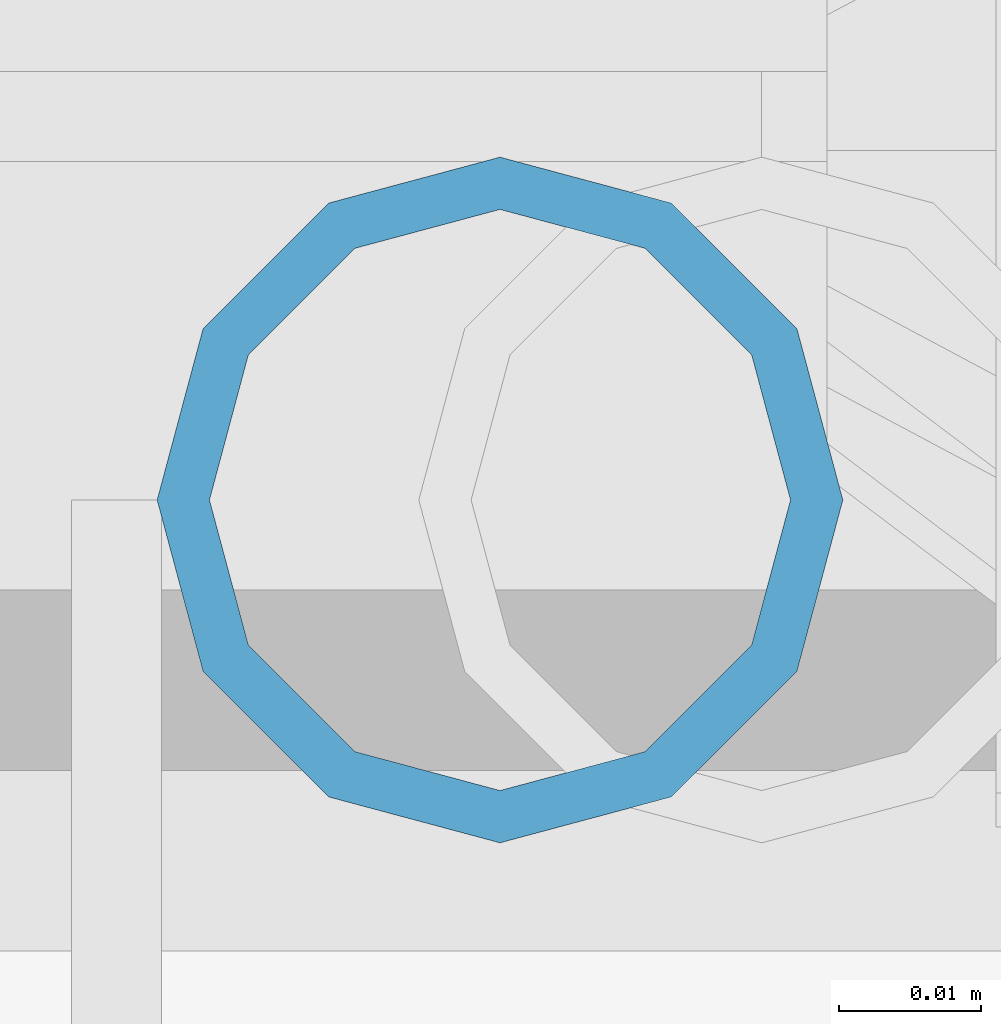
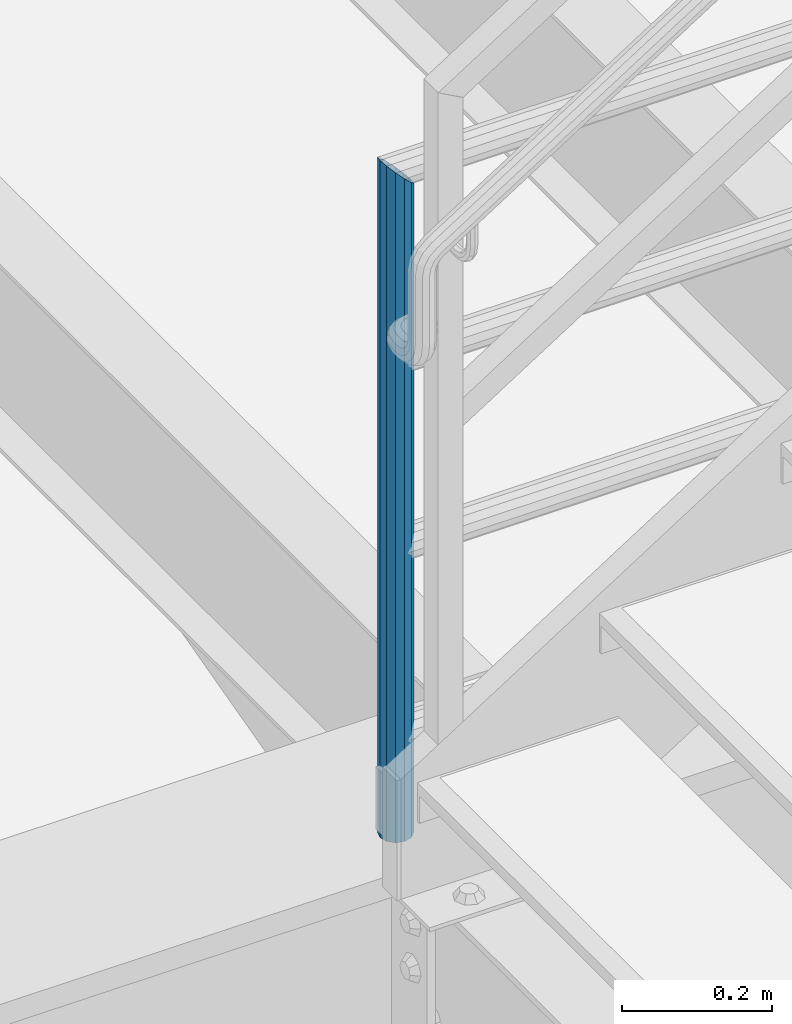
# One storey, part 608 of 1876: 1 column, 1 element without a shape of its own.
"""IFC2X3 building model written with IfcOpenShell, lengths in millimetres."""

from ifc_helpers import new_model, si_unit, frame, origin_with_axes, place, context, subcontext, project, spatial, faceted_brep, material, type_object, element, aggregate, save


model = new_model("IFC2X3")

# Units and contexts
model_context = context("Model", 3, precision=1e-05, world=origin_with_axes())
body_context = subcontext(model_context, "Body", "Model", "MODEL_VIEW")
ifc_project = project(units=[si_unit("LENGTHUNIT", "METRE", prefix="MILLI"), si_unit("AREAUNIT", "SQUARE_METRE"), si_unit("VOLUMEUNIT", "CUBIC_METRE"), si_unit("MASSUNIT", "GRAM", prefix="KILO"), si_unit("TIMEUNIT", "SECOND"), si_unit("PLANEANGLEUNIT", "RADIAN"), si_unit("SOLIDANGLEUNIT", "STERADIAN"), si_unit("THERMODYNAMICTEMPERATUREUNIT", "DEGREE_CELSIUS"), si_unit("LUMINOUSINTENSITYUNIT", "LUMEN")], contexts=[model_context])

# Site, building, storey
site_placement = place(None, origin_with_axes())
site = spatial("IfcSite", under=ifc_project, at=site_placement, CompositionType="ELEMENT")
building_placement = place(site_placement, origin_with_axes())
building = spatial("IfcBuilding", under=site, at=building_placement, Name="Undefined", CompositionType="ELEMENT")
storey_placement = place(building_placement, origin_with_axes())
storey = spatial("IfcBuildingStorey", under=building, at=storey_placement, Name="Undefined", CompositionType="ELEMENT", Elevation=0.0)

# Assembly, column
assembly_placement = place(storey_placement, origin_with_axes())
assembly = element("IfcElementAssembly", 1, at=assembly_placement, inside=storey, Name="RAIL", AssemblyPlace="NOTDEFINED", PredefinedType="RIGID_FRAME")
ifc_material = material()
column_type = type_object("IfcColumnType", Name="PIPE1-1/2SCH40", PredefinedType="NOTDEFINED")
column_placement = place(assembly_placement, frame((1676.40000031139, -4654.55000114554, 5130.8), z_axis=(1.0, 0.0, 0.0), x_axis=(0.0, 0.0, 1.0)))
column = element("IfcColumn", 2, at=column_placement, type_object=column_type, material=ifc_material, Name="POST", ObjectType="PIPE1-1/2SCH40", context=body_context, shape_type="Brep", body=[
    faceted_brep([(0.0, -20.4469999999999, 0.0), (0.0, -17.7076214311803, 10.2235000000001), (1066.1015, -17.7076214311803, 10.2235000000001), (1076.325, -20.4469999999999, 0.0), (0.0, -10.2235000000001, 17.7076214311801), (1058.61737856882, -10.2235000000001, 17.7076214311801), (-1.45519152283669e-11, 0.0, 20.4470000000001), (1055.878, 0.0, 20.4470000000001), (0.0, 10.2235000000001, 17.7076214311801), (1058.61737856882, 10.2235000000001, 17.7076214311801), (0.0, 17.7076214311803, 10.2235000000001), (1066.1015, 17.7076214311803, 10.2235000000001), (0.0, 20.4469999999999, 0.0), (1076.325, 20.4469999999999, 0.0), (0.0, 17.7076214311803, -10.2235000000001), (1086.5485, 17.7076214311803, -10.2235000000001), (0.0, 10.2235000000001, -17.7076214311801), (1094.03262143118, 10.2235000000001, -17.7076214311801), (-1.45519152283669e-11, 0.0, -20.4470000000001), (1096.772, 0.0, -20.4470000000001), (0.0, -10.2235000000001, -17.7076214311801), (1094.03262143118, -10.2235000000001, -17.7076214311801), (0.0, -17.7076214311803, -10.2235000000001), (1086.5485, -17.7076214311803, -10.2235000000001), (0.0, -24.1299999999992, 0.0), (0.0, -20.8971929933184, -12.0649999999996), (1088.39, -20.8971929933184, -12.0649999999996), (1076.325, -24.1300000000001, 0.0), (0.0, -12.0650000000001, -20.8971929933186), (1097.22219299332, -12.0650000000001, -20.8971929933186), (-1.45519152283669e-11, 0.0, -24.130000000001), (1100.455, 0.0, -24.1300000000001), (0.0, 12.0650000000001, -20.8971929933186), (1097.22219299332, 12.0650000000001, -20.8971929933186), (0.0, 20.8971929933184, -12.0649999999996), (1088.39, 20.8971929933184, -12.0649999999996), (0.0, 24.1299999999992, 0.0), (1076.325, 24.1300000000001, 0.0), (0.0, 20.8971929933184, 12.0649999999996), (1064.26, 20.8971929933184, 12.0649999999996), (0.0, 12.0650000000001, 20.8971929933186), (1055.42780700668, 12.0650000000001, 20.8971929933186), (-1.45519152283669e-11, 0.0, 24.130000000001), (1052.195, 0.0, 24.1300000000001), (0.0, -12.0650000000001, 20.8971929933186), (1055.42780700668, -12.0650000000001, 20.8971929933186), (0.0, -20.8971929933184, 12.0649999999996), (1064.26, -20.8971929933184, 12.0649999999996)], [[[0, 1, 2, 3]], [[1, 4, 5, 2]], [[4, 6, 7, 5]], [[6, 8, 9, 7]], [[8, 10, 11, 9]], [[10, 12, 13, 11]], [[12, 14, 15, 13]], [[14, 16, 17, 15]], [[16, 18, 19, 17]], [[18, 20, 21, 19]], [[20, 22, 23, 21]], [[22, 0, 3, 23]], [[24, 25, 26, 27]], [[25, 28, 29, 26]], [[28, 30, 31, 29]], [[30, 32, 33, 31]], [[32, 34, 35, 33]], [[34, 36, 37, 35]], [[36, 38, 39, 37]], [[38, 40, 41, 39]], [[40, 42, 43, 41]], [[42, 44, 45, 43]], [[44, 46, 47, 45]], [[46, 24, 27, 47]], [[29, 31, 33, 35, 37, 39, 41, 43, 45, 47, 27, 26], [5, 7, 9, 11, 13, 15, 17, 19, 21, 23, 3, 2]], [[46, 44, 42, 40, 38, 36, 34, 32, 30, 28, 25, 24], [22, 20, 18, 16, 14, 12, 10, 8, 6, 4, 1, 0]]]),
])
aggregate(assembly, [column])

save(model, "model.ifc")
